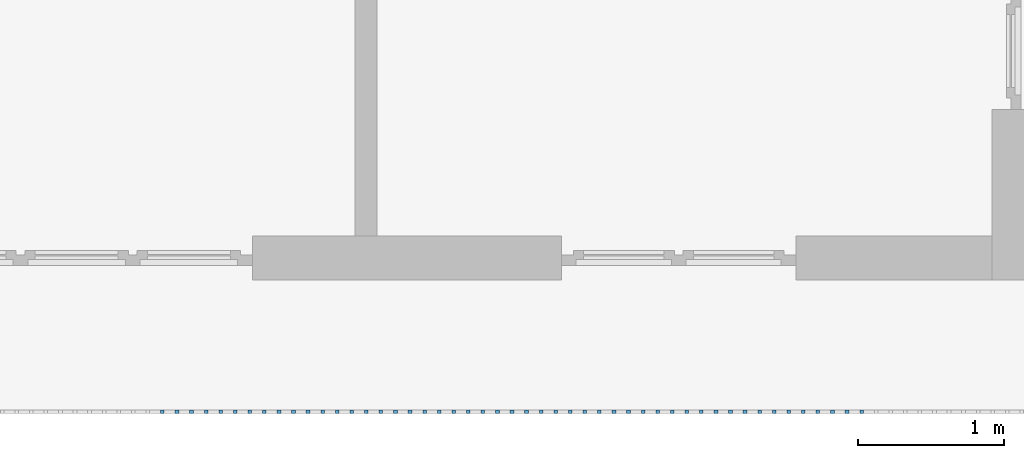
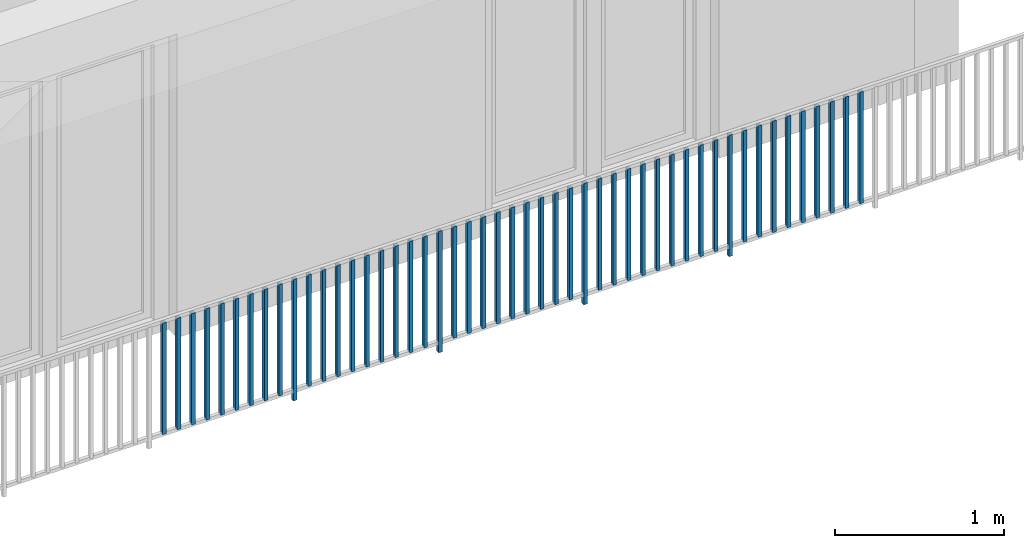
# One storey, part 42 of 54: 49 building element parts, 1 element without a shape of its own.
"""IFC4 building model written with IfcOpenShell, lengths in metres."""

from ifc_helpers import new_model, entity, si_unit, converted_unit, derived_unit, direction, frame, origin_with_axes, place, context, subcontext, project, spatial, polygons, material, type_object, element, aggregate, save


model = new_model("IFC4")

# Units and contexts
model_context = context("Model", 3, precision=1e-05, world=origin_with_axes(), true_north=direction((0.0, 1.0)))
body_context = subcontext(model_context, "Body", "Model", "MODEL_VIEW")
ifc_project = project(units=[si_unit("LENGTHUNIT", "METRE"), si_unit("AREAUNIT", "SQUARE_METRE"), si_unit("VOLUMEUNIT", "CUBIC_METRE"), converted_unit("PLANEANGLEUNIT", "DEGREE", entity("IfcPlaneAngleMeasure", 0.0174532925199), si_unit("PLANEANGLEUNIT", "RADIAN"), dimensions=[0, 0, 0, 0, 0, 0, 0]), converted_unit("TIMEUNIT", "Year", entity("IfcTimeMeasure", 31556926.0), si_unit("TIMEUNIT", "SECOND"), dimensions=[0, 0, 1, 0, 0, 0, 0]), si_unit("MASSUNIT", "GRAM", prefix="KILO"), si_unit("THERMODYNAMICTEMPERATUREUNIT", "DEGREE_CELSIUS"), si_unit("LUMINOUSINTENSITYUNIT", "LUMEN"), si_unit("ENERGYUNIT", "JOULE", prefix="MEGA"), derived_unit("THERMALCONDUCTANCEUNIT", [(si_unit("POWERUNIT", "WATT"), 1), (si_unit("LENGTHUNIT", "METRE"), -1), (si_unit("THERMODYNAMICTEMPERATUREUNIT", "KELVIN"), -1)]), derived_unit("SPECIFICHEATCAPACITYUNIT", [(si_unit("ENERGYUNIT", "JOULE"), 1), (si_unit("MASSUNIT", "GRAM", prefix="KILO"), -1), (si_unit("THERMODYNAMICTEMPERATUREUNIT", "KELVIN"), -1)]), derived_unit("MASSDENSITYUNIT", [(si_unit("MASSUNIT", "GRAM", prefix="KILO"), 1), (si_unit("VOLUMEUNIT", "CUBIC_METRE"), -1)])], contexts=[model_context])

# Site, building, storey, space
site_placement = place(None, origin_with_axes())
site = spatial("IfcSite", under=ifc_project, at=site_placement, CompositionType="ELEMENT")
building_placement = place(site_placement, origin_with_axes())
building = spatial("IfcBuilding", under=site, at=building_placement, CompositionType="ELEMENT")
storey_placement = place(building_placement, frame((0.0, 0.0, 9.18), z_axis=(0.0, 0.0, 1.0), x_axis=(1.0, 0.0, 0.0)))
storey = spatial("IfcBuildingStorey", under=building, at=storey_placement, Name="3. Geschoss", CompositionType="ELEMENT", Elevation=9.18)
space_placement = place(storey_placement, frame((10.2378006196, 9.82118769833, 0.0), z_axis=(0.0, 0.0, 1.0), x_axis=(-1.0, 0.0, 0.0)))
space = spatial("IfcSpace", under=storey, at=space_placement, CompositionType="ELEMENT", PredefinedType="EXTERNAL")

# Railing, building element parts
railing_type = type_object("IfcRailingType", PredefinedType="NOTDEFINED")
railing_placement = place(space_placement, frame((0.0, -7.06315681498e-08, 0.0), z_axis=(0.0, 0.0, 1.0), x_axis=(-1.0, 0.0, 0.0)))
railing = element("IfcRailing", 1, at=railing_placement, inside=space, type_object=railing_type, PredefinedType="NOTDEFINED")
ifc_material = material()
building_element_part_1_placement = place(railing_placement, origin_with_axes())
building_element_part_1 = element("IfcBuildingElementPart", 2, at=building_element_part_1_placement, material=ifc_material, PredefinedType="NOTDEFINED", context=body_context, shape_type="Tessellation", body=[
    polygons([(-6.8515, -20.6625, 0.07), (-6.8515, -20.6375, 0.07), (-6.8515, -20.6375, 0.8775), (-6.8515, -20.6625, 0.8775), (-6.8765, -20.6625, 0.07), (-6.8765, -20.6375, 0.07), (-6.8765, -20.6375, 0.8775), (-6.8765, -20.6625, 0.8775)], [[[1, 2, 3, 4]], [[1, 5, 6, 2]], [[2, 6, 7, 3]], [[4, 3, 7, 8]], [[5, 1, 4, 8]], [[6, 5, 8, 7]]], closed=True),
])
building_element_part_2_placement = place(railing_placement, origin_with_axes())
building_element_part_2 = element("IfcBuildingElementPart", 3, at=building_element_part_2_placement, material=ifc_material, PredefinedType="NOTDEFINED", context=body_context, shape_type="Tessellation", body=[
    polygons([(-6.75202173913, -20.6625, 0.07), (-6.75202173913, -20.6375, 0.07), (-6.75202173913, -20.6375, 0.8775), (-6.75202173913, -20.6625, 0.8775), (-6.77702173913, -20.6625, 0.07), (-6.77702173913, -20.6375, 0.07), (-6.77702173913, -20.6375, 0.8775), (-6.77702173913, -20.6625, 0.8775)], [[[1, 2, 3, 4]], [[1, 5, 6, 2]], [[2, 6, 7, 3]], [[4, 3, 7, 8]], [[5, 1, 4, 8]], [[6, 5, 8, 7]]], closed=True),
])
building_element_part_3_placement = place(railing_placement, origin_with_axes())
building_element_part_3 = element("IfcBuildingElementPart", 4, at=building_element_part_3_placement, material=ifc_material, PredefinedType="NOTDEFINED", context=body_context, shape_type="Tessellation", body=[
    polygons([(-6.65254347826, -20.6625, 0.07), (-6.65254347826, -20.6375, 0.07), (-6.65254347826, -20.6375, 0.8775), (-6.65254347826, -20.6625, 0.8775), (-6.67754347826, -20.6625, 0.07), (-6.67754347826, -20.6375, 0.07), (-6.67754347826, -20.6375, 0.8775), (-6.67754347826, -20.6625, 0.8775)], [[[1, 2, 3, 4]], [[1, 5, 6, 2]], [[2, 6, 7, 3]], [[4, 3, 7, 8]], [[5, 1, 4, 8]], [[6, 5, 8, 7]]], closed=True),
])
building_element_part_4_placement = place(railing_placement, origin_with_axes())
building_element_part_4 = element("IfcBuildingElementPart", 5, at=building_element_part_4_placement, material=ifc_material, PredefinedType="NOTDEFINED", context=body_context, shape_type="Tessellation", body=[
    polygons([(-6.55306521739, -20.6625, 0.07), (-6.55306521739, -20.6375, 0.07), (-6.55306521739, -20.6375, 0.8775), (-6.55306521739, -20.6625, 0.8775), (-6.57806521739, -20.6625, 0.07), (-6.57806521739, -20.6375, 0.07), (-6.57806521739, -20.6375, 0.8775), (-6.57806521739, -20.6625, 0.8775)], [[[1, 2, 3, 4]], [[1, 5, 6, 2]], [[2, 6, 7, 3]], [[4, 3, 7, 8]], [[5, 1, 4, 8]], [[6, 5, 8, 7]]], closed=True),
])
building_element_part_5_placement = place(railing_placement, origin_with_axes())
building_element_part_5 = element("IfcBuildingElementPart", 6, at=building_element_part_5_placement, material=ifc_material, PredefinedType="NOTDEFINED", context=body_context, shape_type="Tessellation", body=[
    polygons([(-6.45358695652, -20.6625, 0.07), (-6.45358695652, -20.6375, 0.07), (-6.45358695652, -20.6375, 0.8775), (-6.45358695652, -20.6625, 0.8775), (-6.47858695652, -20.6625, 0.07), (-6.47858695652, -20.6375, 0.07), (-6.47858695652, -20.6375, 0.8775), (-6.47858695652, -20.6625, 0.8775)], [[[1, 2, 3, 4]], [[1, 5, 6, 2]], [[2, 6, 7, 3]], [[4, 3, 7, 8]], [[5, 1, 4, 8]], [[6, 5, 8, 7]]], closed=True),
])
building_element_part_6_placement = place(railing_placement, origin_with_axes())
building_element_part_6 = element("IfcBuildingElementPart", 7, at=building_element_part_6_placement, material=ifc_material, PredefinedType="NOTDEFINED", context=body_context, shape_type="Tessellation", body=[
    polygons([(-6.35410869565, -20.6625, 0.07), (-6.35410869565, -20.6375, 0.07), (-6.35410869565, -20.6375, 0.8775), (-6.35410869565, -20.6625, 0.8775), (-6.37910869565, -20.6625, 0.07), (-6.37910869565, -20.6375, 0.07), (-6.37910869565, -20.6375, 0.8775), (-6.37910869565, -20.6625, 0.8775)], [[[1, 2, 3, 4]], [[1, 5, 6, 2]], [[2, 6, 7, 3]], [[4, 3, 7, 8]], [[5, 1, 4, 8]], [[6, 5, 8, 7]]], closed=True),
])
building_element_part_7_placement = place(railing_placement, origin_with_axes())
building_element_part_7 = element("IfcBuildingElementPart", 8, at=building_element_part_7_placement, material=ifc_material, PredefinedType="NOTDEFINED", context=body_context, shape_type="Tessellation", body=[
    polygons([(-6.25463043478, -20.6625, 0.07), (-6.25463043478, -20.6375, 0.07), (-6.25463043478, -20.6375, 0.8775), (-6.25463043478, -20.6625, 0.8775), (-6.27963043478, -20.6625, 0.07), (-6.27963043478, -20.6375, 0.07), (-6.27963043478, -20.6375, 0.8775), (-6.27963043478, -20.6625, 0.8775)], [[[1, 2, 3, 4]], [[1, 5, 6, 2]], [[2, 6, 7, 3]], [[4, 3, 7, 8]], [[5, 1, 4, 8]], [[6, 5, 8, 7]]], closed=True),
])
building_element_part_8_placement = place(railing_placement, origin_with_axes())
building_element_part_8 = element("IfcBuildingElementPart", 9, at=building_element_part_8_placement, material=ifc_material, PredefinedType="NOTDEFINED", context=body_context, shape_type="Tessellation", body=[
    polygons([(-6.15515217391, -20.6625, 0.07), (-6.15515217391, -20.6375, 0.07), (-6.15515217391, -20.6375, 0.8775), (-6.15515217391, -20.6625, 0.8775), (-6.18015217391, -20.6625, 0.07), (-6.18015217391, -20.6375, 0.07), (-6.18015217391, -20.6375, 0.8775), (-6.18015217391, -20.6625, 0.8775)], [[[1, 2, 3, 4]], [[1, 5, 6, 2]], [[2, 6, 7, 3]], [[4, 3, 7, 8]], [[5, 1, 4, 8]], [[6, 5, 8, 7]]], closed=True),
])
building_element_part_9_placement = place(railing_placement, origin_with_axes())
building_element_part_9 = element("IfcBuildingElementPart", 10, at=building_element_part_9_placement, material=ifc_material, PredefinedType="NOTDEFINED", context=body_context, shape_type="Tessellation", body=[
    polygons([(-6.05567391304, -20.6625, 0.07), (-6.05567391304, -20.6375, 0.07), (-6.05567391304, -20.6375, 0.8775), (-6.05567391304, -20.6625, 0.8775), (-6.08067391304, -20.6625, 0.07), (-6.08067391304, -20.6375, 0.07), (-6.08067391304, -20.6375, 0.8775), (-6.08067391304, -20.6625, 0.8775)], [[[1, 2, 3, 4]], [[1, 5, 6, 2]], [[2, 6, 7, 3]], [[4, 3, 7, 8]], [[5, 1, 4, 8]], [[6, 5, 8, 7]]], closed=True),
])
building_element_part_10_placement = place(railing_placement, origin_with_axes())
building_element_part_10 = element("IfcBuildingElementPart", 11, at=building_element_part_10_placement, material=ifc_material, PredefinedType="NOTDEFINED", context=body_context, shape_type="Tessellation", body=[
    polygons([(-5.95619565217, -20.6625, 0.0), (-5.95619565217, -20.6375, 0.0), (-5.95619565217, -20.6375, 0.88), (-5.95619565217, -20.6625, 0.88), (-5.98119565217, -20.6625, 0.0), (-5.98119565217, -20.6375, 0.0), (-5.98119565217, -20.6375, 0.88), (-5.98119565217, -20.6625, 0.88)], [[[1, 2, 3, 4]], [[1, 5, 6, 2]], [[2, 6, 7, 3]], [[4, 3, 7, 8]], [[5, 1, 4, 8]], [[6, 5, 8, 7]]], closed=True),
])
building_element_part_11_placement = place(railing_placement, origin_with_axes())
building_element_part_11 = element("IfcBuildingElementPart", 12, at=building_element_part_11_placement, material=ifc_material, PredefinedType="NOTDEFINED", context=body_context, shape_type="Tessellation", body=[
    polygons([(-5.8567173913, -20.6625, 0.07), (-5.8567173913, -20.6375, 0.07), (-5.8567173913, -20.6375, 0.8775), (-5.8567173913, -20.6625, 0.8775), (-5.8817173913, -20.6625, 0.07), (-5.8817173913, -20.6375, 0.07), (-5.8817173913, -20.6375, 0.8775), (-5.8817173913, -20.6625, 0.8775)], [[[1, 2, 3, 4]], [[1, 5, 6, 2]], [[2, 6, 7, 3]], [[4, 3, 7, 8]], [[5, 1, 4, 8]], [[6, 5, 8, 7]]], closed=True),
])
building_element_part_12_placement = place(railing_placement, origin_with_axes())
building_element_part_12 = element("IfcBuildingElementPart", 13, at=building_element_part_12_placement, material=ifc_material, PredefinedType="NOTDEFINED", context=body_context, shape_type="Tessellation", body=[
    polygons([(-5.75723913043, -20.6625, 0.07), (-5.75723913043, -20.6375, 0.07), (-5.75723913043, -20.6375, 0.8775), (-5.75723913043, -20.6625, 0.8775), (-5.78223913043, -20.6625, 0.07), (-5.78223913043, -20.6375, 0.07), (-5.78223913043, -20.6375, 0.8775), (-5.78223913043, -20.6625, 0.8775)], [[[1, 2, 3, 4]], [[1, 5, 6, 2]], [[2, 6, 7, 3]], [[4, 3, 7, 8]], [[5, 1, 4, 8]], [[6, 5, 8, 7]]], closed=True),
])
building_element_part_13_placement = place(railing_placement, origin_with_axes())
building_element_part_13 = element("IfcBuildingElementPart", 14, at=building_element_part_13_placement, material=ifc_material, PredefinedType="NOTDEFINED", context=body_context, shape_type="Tessellation", body=[
    polygons([(-5.65776086957, -20.6625, 0.07), (-5.65776086957, -20.6375, 0.07), (-5.65776086957, -20.6375, 0.8775), (-5.65776086957, -20.6625, 0.8775), (-5.68276086957, -20.6625, 0.07), (-5.68276086957, -20.6375, 0.07), (-5.68276086957, -20.6375, 0.8775), (-5.68276086957, -20.6625, 0.8775)], [[[1, 2, 3, 4]], [[1, 5, 6, 2]], [[2, 6, 7, 3]], [[4, 3, 7, 8]], [[5, 1, 4, 8]], [[6, 5, 8, 7]]], closed=True),
])
building_element_part_14_placement = place(railing_placement, origin_with_axes())
building_element_part_14 = element("IfcBuildingElementPart", 15, at=building_element_part_14_placement, material=ifc_material, PredefinedType="NOTDEFINED", context=body_context, shape_type="Tessellation", body=[
    polygons([(-5.5582826087, -20.6625, 0.07), (-5.5582826087, -20.6375, 0.07), (-5.5582826087, -20.6375, 0.8775), (-5.5582826087, -20.6625, 0.8775), (-5.5832826087, -20.6625, 0.07), (-5.5832826087, -20.6375, 0.07), (-5.5832826087, -20.6375, 0.8775), (-5.5832826087, -20.6625, 0.8775)], [[[1, 2, 3, 4]], [[1, 5, 6, 2]], [[2, 6, 7, 3]], [[4, 3, 7, 8]], [[5, 1, 4, 8]], [[6, 5, 8, 7]]], closed=True),
])
building_element_part_15_placement = place(railing_placement, origin_with_axes())
building_element_part_15 = element("IfcBuildingElementPart", 16, at=building_element_part_15_placement, material=ifc_material, PredefinedType="NOTDEFINED", context=body_context, shape_type="Tessellation", body=[
    polygons([(-5.45880434783, -20.6625, 0.07), (-5.45880434783, -20.6375, 0.07), (-5.45880434783, -20.6375, 0.8775), (-5.45880434783, -20.6625, 0.8775), (-5.48380434783, -20.6625, 0.07), (-5.48380434783, -20.6375, 0.07), (-5.48380434783, -20.6375, 0.8775), (-5.48380434783, -20.6625, 0.8775)], [[[1, 2, 3, 4]], [[1, 5, 6, 2]], [[2, 6, 7, 3]], [[4, 3, 7, 8]], [[5, 1, 4, 8]], [[6, 5, 8, 7]]], closed=True),
])
building_element_part_16_placement = place(railing_placement, origin_with_axes())
building_element_part_16 = element("IfcBuildingElementPart", 17, at=building_element_part_16_placement, material=ifc_material, PredefinedType="NOTDEFINED", context=body_context, shape_type="Tessellation", body=[
    polygons([(-5.35932608696, -20.6625, 0.07), (-5.35932608696, -20.6375, 0.07), (-5.35932608696, -20.6375, 0.8775), (-5.35932608696, -20.6625, 0.8775), (-5.38432608696, -20.6625, 0.07), (-5.38432608696, -20.6375, 0.07), (-5.38432608696, -20.6375, 0.8775), (-5.38432608696, -20.6625, 0.8775)], [[[1, 2, 3, 4]], [[1, 5, 6, 2]], [[2, 6, 7, 3]], [[4, 3, 7, 8]], [[5, 1, 4, 8]], [[6, 5, 8, 7]]], closed=True),
])
building_element_part_17_placement = place(railing_placement, origin_with_axes())
building_element_part_17 = element("IfcBuildingElementPart", 18, at=building_element_part_17_placement, material=ifc_material, PredefinedType="NOTDEFINED", context=body_context, shape_type="Tessellation", body=[
    polygons([(-5.25984782609, -20.6625, 0.07), (-5.25984782609, -20.6375, 0.07), (-5.25984782609, -20.6375, 0.8775), (-5.25984782609, -20.6625, 0.8775), (-5.28484782609, -20.6625, 0.07), (-5.28484782609, -20.6375, 0.07), (-5.28484782609, -20.6375, 0.8775), (-5.28484782609, -20.6625, 0.8775)], [[[1, 2, 3, 4]], [[1, 5, 6, 2]], [[2, 6, 7, 3]], [[4, 3, 7, 8]], [[5, 1, 4, 8]], [[6, 5, 8, 7]]], closed=True),
])
building_element_part_18_placement = place(railing_placement, origin_with_axes())
building_element_part_18 = element("IfcBuildingElementPart", 19, at=building_element_part_18_placement, material=ifc_material, PredefinedType="NOTDEFINED", context=body_context, shape_type="Tessellation", body=[
    polygons([(-5.16036956522, -20.6625, 0.07), (-5.16036956522, -20.6375, 0.07), (-5.16036956522, -20.6375, 0.8775), (-5.16036956522, -20.6625, 0.8775), (-5.18536956522, -20.6625, 0.07), (-5.18536956522, -20.6375, 0.07), (-5.18536956522, -20.6375, 0.8775), (-5.18536956522, -20.6625, 0.8775)], [[[1, 2, 3, 4]], [[1, 5, 6, 2]], [[2, 6, 7, 3]], [[4, 3, 7, 8]], [[5, 1, 4, 8]], [[6, 5, 8, 7]]], closed=True),
])
building_element_part_19_placement = place(railing_placement, origin_with_axes())
building_element_part_19 = element("IfcBuildingElementPart", 20, at=building_element_part_19_placement, material=ifc_material, PredefinedType="NOTDEFINED", context=body_context, shape_type="Tessellation", body=[
    polygons([(-5.06089130435, -20.6625, 0.07), (-5.06089130435, -20.6375, 0.07), (-5.06089130435, -20.6375, 0.8775), (-5.06089130435, -20.6625, 0.8775), (-5.08589130435, -20.6625, 0.07), (-5.08589130435, -20.6375, 0.07), (-5.08589130435, -20.6375, 0.8775), (-5.08589130435, -20.6625, 0.8775)], [[[1, 2, 3, 4]], [[1, 5, 6, 2]], [[2, 6, 7, 3]], [[4, 3, 7, 8]], [[5, 1, 4, 8]], [[6, 5, 8, 7]]], closed=True),
])
building_element_part_20_placement = place(railing_placement, origin_with_axes())
building_element_part_20 = element("IfcBuildingElementPart", 21, at=building_element_part_20_placement, material=ifc_material, PredefinedType="NOTDEFINED", context=body_context, shape_type="Tessellation", body=[
    polygons([(-4.96141304348, -20.6625, 0.0), (-4.96141304348, -20.6375, 0.0), (-4.96141304348, -20.6375, 0.88), (-4.96141304348, -20.6625, 0.88), (-4.98641304348, -20.6625, 0.0), (-4.98641304348, -20.6375, 0.0), (-4.98641304348, -20.6375, 0.88), (-4.98641304348, -20.6625, 0.88)], [[[1, 2, 3, 4]], [[1, 5, 6, 2]], [[2, 6, 7, 3]], [[4, 3, 7, 8]], [[5, 1, 4, 8]], [[6, 5, 8, 7]]], closed=True),
])
building_element_part_21_placement = place(railing_placement, origin_with_axes())
building_element_part_21 = element("IfcBuildingElementPart", 22, at=building_element_part_21_placement, material=ifc_material, PredefinedType="NOTDEFINED", context=body_context, shape_type="Tessellation", body=[
    polygons([(-4.86193478261, -20.6625, 0.07), (-4.86193478261, -20.6375, 0.07), (-4.86193478261, -20.6375, 0.8775), (-4.86193478261, -20.6625, 0.8775), (-4.88693478261, -20.6625, 0.07), (-4.88693478261, -20.6375, 0.07), (-4.88693478261, -20.6375, 0.8775), (-4.88693478261, -20.6625, 0.8775)], [[[1, 2, 3, 4]], [[1, 5, 6, 2]], [[2, 6, 7, 3]], [[4, 3, 7, 8]], [[5, 1, 4, 8]], [[6, 5, 8, 7]]], closed=True),
])
building_element_part_22_placement = place(railing_placement, origin_with_axes())
building_element_part_22 = element("IfcBuildingElementPart", 23, at=building_element_part_22_placement, material=ifc_material, PredefinedType="NOTDEFINED", context=body_context, shape_type="Tessellation", body=[
    polygons([(-4.76245652174, -20.6625, 0.07), (-4.76245652174, -20.6375, 0.07), (-4.76245652174, -20.6375, 0.8775), (-4.76245652174, -20.6625, 0.8775), (-4.78745652174, -20.6625, 0.07), (-4.78745652174, -20.6375, 0.07), (-4.78745652174, -20.6375, 0.8775), (-4.78745652174, -20.6625, 0.8775)], [[[1, 2, 3, 4]], [[1, 5, 6, 2]], [[2, 6, 7, 3]], [[4, 3, 7, 8]], [[5, 1, 4, 8]], [[6, 5, 8, 7]]], closed=True),
])
building_element_part_23_placement = place(railing_placement, origin_with_axes())
building_element_part_23 = element("IfcBuildingElementPart", 24, at=building_element_part_23_placement, material=ifc_material, PredefinedType="NOTDEFINED", context=body_context, shape_type="Tessellation", body=[
    polygons([(-4.66297826087, -20.6625, 0.07), (-4.66297826087, -20.6375, 0.07), (-4.66297826087, -20.6375, 0.8775), (-4.66297826087, -20.6625, 0.8775), (-4.68797826087, -20.6625, 0.07), (-4.68797826087, -20.6375, 0.07), (-4.68797826087, -20.6375, 0.8775), (-4.68797826087, -20.6625, 0.8775)], [[[1, 2, 3, 4]], [[1, 5, 6, 2]], [[2, 6, 7, 3]], [[4, 3, 7, 8]], [[5, 1, 4, 8]], [[6, 5, 8, 7]]], closed=True),
])
building_element_part_24_placement = place(railing_placement, origin_with_axes())
building_element_part_24 = element("IfcBuildingElementPart", 25, at=building_element_part_24_placement, material=ifc_material, PredefinedType="NOTDEFINED", context=body_context, shape_type="Tessellation", body=[
    polygons([(-4.5635, -20.6625, 0.07), (-4.5635, -20.6375, 0.07), (-4.5635, -20.6375, 0.8775), (-4.5635, -20.6625, 0.8775), (-4.5885, -20.6625, 0.07), (-4.5885, -20.6375, 0.07), (-4.5885, -20.6375, 0.8775), (-4.5885, -20.6625, 0.8775)], [[[1, 2, 3, 4]], [[1, 5, 6, 2]], [[2, 6, 7, 3]], [[4, 3, 7, 8]], [[5, 1, 4, 8]], [[6, 5, 8, 7]]], closed=True),
])
building_element_part_25_placement = place(railing_placement, origin_with_axes())
building_element_part_25 = element("IfcBuildingElementPart", 26, at=building_element_part_25_placement, material=ifc_material, PredefinedType="NOTDEFINED", context=body_context, shape_type="Tessellation", body=[
    polygons([(-4.46402173913, -20.6625, 0.07), (-4.46402173913, -20.6375, 0.07), (-4.46402173913, -20.6375, 0.8775), (-4.46402173913, -20.6625, 0.8775), (-4.48902173913, -20.6625, 0.07), (-4.48902173913, -20.6375, 0.07), (-4.48902173913, -20.6375, 0.8775), (-4.48902173913, -20.6625, 0.8775)], [[[1, 2, 3, 4]], [[1, 5, 6, 2]], [[2, 6, 7, 3]], [[4, 3, 7, 8]], [[5, 1, 4, 8]], [[6, 5, 8, 7]]], closed=True),
])
building_element_part_26_placement = place(railing_placement, origin_with_axes())
building_element_part_26 = element("IfcBuildingElementPart", 27, at=building_element_part_26_placement, material=ifc_material, PredefinedType="NOTDEFINED", context=body_context, shape_type="Tessellation", body=[
    polygons([(-4.36454347826, -20.6625, 0.07), (-4.36454347826, -20.6375, 0.07), (-4.36454347826, -20.6375, 0.8775), (-4.36454347826, -20.6625, 0.8775), (-4.38954347826, -20.6625, 0.07), (-4.38954347826, -20.6375, 0.07), (-4.38954347826, -20.6375, 0.8775), (-4.38954347826, -20.6625, 0.8775)], [[[1, 2, 3, 4]], [[1, 5, 6, 2]], [[2, 6, 7, 3]], [[4, 3, 7, 8]], [[5, 1, 4, 8]], [[6, 5, 8, 7]]], closed=True),
])
building_element_part_27_placement = place(railing_placement, origin_with_axes())
building_element_part_27 = element("IfcBuildingElementPart", 28, at=building_element_part_27_placement, material=ifc_material, PredefinedType="NOTDEFINED", context=body_context, shape_type="Tessellation", body=[
    polygons([(-4.26506521739, -20.6625, 0.07), (-4.26506521739, -20.6375, 0.07), (-4.26506521739, -20.6375, 0.8775), (-4.26506521739, -20.6625, 0.8775), (-4.29006521739, -20.6625, 0.07), (-4.29006521739, -20.6375, 0.07), (-4.29006521739, -20.6375, 0.8775), (-4.29006521739, -20.6625, 0.8775)], [[[1, 2, 3, 4]], [[1, 5, 6, 2]], [[2, 6, 7, 3]], [[4, 3, 7, 8]], [[5, 1, 4, 8]], [[6, 5, 8, 7]]], closed=True),
])
building_element_part_28_placement = place(railing_placement, origin_with_axes())
building_element_part_28 = element("IfcBuildingElementPart", 29, at=building_element_part_28_placement, material=ifc_material, PredefinedType="NOTDEFINED", context=body_context, shape_type="Tessellation", body=[
    polygons([(-4.16558695652, -20.6625, 0.07), (-4.16558695652, -20.6375, 0.07), (-4.16558695652, -20.6375, 0.8775), (-4.16558695652, -20.6625, 0.8775), (-4.19058695652, -20.6625, 0.07), (-4.19058695652, -20.6375, 0.07), (-4.19058695652, -20.6375, 0.8775), (-4.19058695652, -20.6625, 0.8775)], [[[1, 2, 3, 4]], [[1, 5, 6, 2]], [[2, 6, 7, 3]], [[4, 3, 7, 8]], [[5, 1, 4, 8]], [[6, 5, 8, 7]]], closed=True),
])
building_element_part_29_placement = place(railing_placement, origin_with_axes())
building_element_part_29 = element("IfcBuildingElementPart", 30, at=building_element_part_29_placement, material=ifc_material, PredefinedType="NOTDEFINED", context=body_context, shape_type="Tessellation", body=[
    polygons([(-4.06610869565, -20.6625, 0.07), (-4.06610869565, -20.6375, 0.07), (-4.06610869565, -20.6375, 0.8775), (-4.06610869565, -20.6625, 0.8775), (-4.09110869565, -20.6625, 0.07), (-4.09110869565, -20.6375, 0.07), (-4.09110869565, -20.6375, 0.8775), (-4.09110869565, -20.6625, 0.8775)], [[[1, 2, 3, 4]], [[1, 5, 6, 2]], [[2, 6, 7, 3]], [[4, 3, 7, 8]], [[5, 1, 4, 8]], [[6, 5, 8, 7]]], closed=True),
])
building_element_part_30_placement = place(railing_placement, origin_with_axes())
building_element_part_30 = element("IfcBuildingElementPart", 31, at=building_element_part_30_placement, material=ifc_material, PredefinedType="NOTDEFINED", context=body_context, shape_type="Tessellation", body=[
    polygons([(-3.96663043478, -20.6625, 0.0), (-3.96663043478, -20.6375, 0.0), (-3.96663043478, -20.6375, 0.88), (-3.96663043478, -20.6625, 0.88), (-3.99163043478, -20.6625, 0.0), (-3.99163043478, -20.6375, 0.0), (-3.99163043478, -20.6375, 0.88), (-3.99163043478, -20.6625, 0.88)], [[[1, 2, 3, 4]], [[1, 5, 6, 2]], [[2, 6, 7, 3]], [[4, 3, 7, 8]], [[5, 1, 4, 8]], [[6, 5, 8, 7]]], closed=True),
])
building_element_part_31_placement = place(railing_placement, origin_with_axes())
building_element_part_31 = element("IfcBuildingElementPart", 32, at=building_element_part_31_placement, material=ifc_material, PredefinedType="NOTDEFINED", context=body_context, shape_type="Tessellation", body=[
    polygons([(-3.86715217391, -20.6625, 0.07), (-3.86715217391, -20.6375, 0.07), (-3.86715217391, -20.6375, 0.8775), (-3.86715217391, -20.6625, 0.8775), (-3.89215217391, -20.6625, 0.07), (-3.89215217391, -20.6375, 0.07), (-3.89215217391, -20.6375, 0.8775), (-3.89215217391, -20.6625, 0.8775)], [[[1, 2, 3, 4]], [[1, 5, 6, 2]], [[2, 6, 7, 3]], [[4, 3, 7, 8]], [[5, 1, 4, 8]], [[6, 5, 8, 7]]], closed=True),
])
building_element_part_32_placement = place(railing_placement, origin_with_axes())
building_element_part_32 = element("IfcBuildingElementPart", 33, at=building_element_part_32_placement, material=ifc_material, PredefinedType="NOTDEFINED", context=body_context, shape_type="Tessellation", body=[
    polygons([(-3.76767391304, -20.6625, 0.07), (-3.76767391304, -20.6375, 0.07), (-3.76767391304, -20.6375, 0.8775), (-3.76767391304, -20.6625, 0.8775), (-3.79267391304, -20.6625, 0.07), (-3.79267391304, -20.6375, 0.07), (-3.79267391304, -20.6375, 0.8775), (-3.79267391304, -20.6625, 0.8775)], [[[1, 2, 3, 4]], [[1, 5, 6, 2]], [[2, 6, 7, 3]], [[4, 3, 7, 8]], [[5, 1, 4, 8]], [[6, 5, 8, 7]]], closed=True),
])
building_element_part_33_placement = place(railing_placement, origin_with_axes())
building_element_part_33 = element("IfcBuildingElementPart", 34, at=building_element_part_33_placement, material=ifc_material, PredefinedType="NOTDEFINED", context=body_context, shape_type="Tessellation", body=[
    polygons([(-3.66819565217, -20.6625, 0.07), (-3.66819565217, -20.6375, 0.07), (-3.66819565217, -20.6375, 0.8775), (-3.66819565217, -20.6625, 0.8775), (-3.69319565217, -20.6625, 0.07), (-3.69319565217, -20.6375, 0.07), (-3.69319565217, -20.6375, 0.8775), (-3.69319565217, -20.6625, 0.8775)], [[[1, 2, 3, 4]], [[1, 5, 6, 2]], [[2, 6, 7, 3]], [[4, 3, 7, 8]], [[5, 1, 4, 8]], [[6, 5, 8, 7]]], closed=True),
])
building_element_part_34_placement = place(railing_placement, origin_with_axes())
building_element_part_34 = element("IfcBuildingElementPart", 35, at=building_element_part_34_placement, material=ifc_material, PredefinedType="NOTDEFINED", context=body_context, shape_type="Tessellation", body=[
    polygons([(-3.5687173913, -20.6625, 0.07), (-3.5687173913, -20.6375, 0.07), (-3.5687173913, -20.6375, 0.8775), (-3.5687173913, -20.6625, 0.8775), (-3.5937173913, -20.6625, 0.07), (-3.5937173913, -20.6375, 0.07), (-3.5937173913, -20.6375, 0.8775), (-3.5937173913, -20.6625, 0.8775)], [[[1, 2, 3, 4]], [[1, 5, 6, 2]], [[2, 6, 7, 3]], [[4, 3, 7, 8]], [[5, 1, 4, 8]], [[6, 5, 8, 7]]], closed=True),
])
building_element_part_35_placement = place(railing_placement, origin_with_axes())
building_element_part_35 = element("IfcBuildingElementPart", 36, at=building_element_part_35_placement, material=ifc_material, PredefinedType="NOTDEFINED", context=body_context, shape_type="Tessellation", body=[
    polygons([(-3.46923913043, -20.6625, 0.07), (-3.46923913043, -20.6375, 0.07), (-3.46923913043, -20.6375, 0.8775), (-3.46923913043, -20.6625, 0.8775), (-3.49423913043, -20.6625, 0.07), (-3.49423913043, -20.6375, 0.07), (-3.49423913043, -20.6375, 0.8775), (-3.49423913043, -20.6625, 0.8775)], [[[1, 2, 3, 4]], [[1, 5, 6, 2]], [[2, 6, 7, 3]], [[4, 3, 7, 8]], [[5, 1, 4, 8]], [[6, 5, 8, 7]]], closed=True),
])
building_element_part_36_placement = place(railing_placement, origin_with_axes())
building_element_part_36 = element("IfcBuildingElementPart", 37, at=building_element_part_36_placement, material=ifc_material, PredefinedType="NOTDEFINED", context=body_context, shape_type="Tessellation", body=[
    polygons([(-3.36976086957, -20.6625, 0.07), (-3.36976086957, -20.6375, 0.07), (-3.36976086957, -20.6375, 0.8775), (-3.36976086957, -20.6625, 0.8775), (-3.39476086957, -20.6625, 0.07), (-3.39476086957, -20.6375, 0.07), (-3.39476086957, -20.6375, 0.8775), (-3.39476086957, -20.6625, 0.8775)], [[[1, 2, 3, 4]], [[1, 5, 6, 2]], [[2, 6, 7, 3]], [[4, 3, 7, 8]], [[5, 1, 4, 8]], [[6, 5, 8, 7]]], closed=True),
])
building_element_part_37_placement = place(railing_placement, origin_with_axes())
building_element_part_37 = element("IfcBuildingElementPart", 38, at=building_element_part_37_placement, material=ifc_material, PredefinedType="NOTDEFINED", context=body_context, shape_type="Tessellation", body=[
    polygons([(-3.2702826087, -20.6625, 0.07), (-3.2702826087, -20.6375, 0.07), (-3.2702826087, -20.6375, 0.8775), (-3.2702826087, -20.6625, 0.8775), (-3.2952826087, -20.6625, 0.07), (-3.2952826087, -20.6375, 0.07), (-3.2952826087, -20.6375, 0.8775), (-3.2952826087, -20.6625, 0.8775)], [[[1, 2, 3, 4]], [[1, 5, 6, 2]], [[2, 6, 7, 3]], [[4, 3, 7, 8]], [[5, 1, 4, 8]], [[6, 5, 8, 7]]], closed=True),
])
building_element_part_38_placement = place(railing_placement, origin_with_axes())
building_element_part_38 = element("IfcBuildingElementPart", 39, at=building_element_part_38_placement, material=ifc_material, PredefinedType="NOTDEFINED", context=body_context, shape_type="Tessellation", body=[
    polygons([(-3.17080434783, -20.6625, 0.07), (-3.17080434783, -20.6375, 0.07), (-3.17080434783, -20.6375, 0.8775), (-3.17080434783, -20.6625, 0.8775), (-3.19580434783, -20.6625, 0.07), (-3.19580434783, -20.6375, 0.07), (-3.19580434783, -20.6375, 0.8775), (-3.19580434783, -20.6625, 0.8775)], [[[1, 2, 3, 4]], [[1, 5, 6, 2]], [[2, 6, 7, 3]], [[4, 3, 7, 8]], [[5, 1, 4, 8]], [[6, 5, 8, 7]]], closed=True),
])
building_element_part_39_placement = place(railing_placement, origin_with_axes())
building_element_part_39 = element("IfcBuildingElementPart", 40, at=building_element_part_39_placement, material=ifc_material, PredefinedType="NOTDEFINED", context=body_context, shape_type="Tessellation", body=[
    polygons([(-3.07132608696, -20.6625, 0.07), (-3.07132608696, -20.6375, 0.07), (-3.07132608696, -20.6375, 0.8775), (-3.07132608696, -20.6625, 0.8775), (-3.09632608696, -20.6625, 0.07), (-3.09632608696, -20.6375, 0.07), (-3.09632608696, -20.6375, 0.8775), (-3.09632608696, -20.6625, 0.8775)], [[[1, 2, 3, 4]], [[1, 5, 6, 2]], [[2, 6, 7, 3]], [[4, 3, 7, 8]], [[5, 1, 4, 8]], [[6, 5, 8, 7]]], closed=True),
])
building_element_part_40_placement = place(railing_placement, origin_with_axes())
building_element_part_40 = element("IfcBuildingElementPart", 41, at=building_element_part_40_placement, material=ifc_material, PredefinedType="NOTDEFINED", context=body_context, shape_type="Tessellation", body=[
    polygons([(-2.97184782609, -20.6625, 0.0), (-2.97184782609, -20.6375, 0.0), (-2.97184782609, -20.6375, 0.88), (-2.97184782609, -20.6625, 0.88), (-2.99684782609, -20.6625, 0.0), (-2.99684782609, -20.6375, 0.0), (-2.99684782609, -20.6375, 0.88), (-2.99684782609, -20.6625, 0.88)], [[[1, 2, 3, 4]], [[1, 5, 6, 2]], [[2, 6, 7, 3]], [[4, 3, 7, 8]], [[5, 1, 4, 8]], [[6, 5, 8, 7]]], closed=True),
])
building_element_part_41_placement = place(railing_placement, origin_with_axes())
building_element_part_41 = element("IfcBuildingElementPart", 42, at=building_element_part_41_placement, material=ifc_material, PredefinedType="NOTDEFINED", context=body_context, shape_type="Tessellation", body=[
    polygons([(-2.87236956522, -20.6625, 0.07), (-2.87236956522, -20.6375, 0.07), (-2.87236956522, -20.6375, 0.8775), (-2.87236956522, -20.6625, 0.8775), (-2.89736956522, -20.6625, 0.07), (-2.89736956522, -20.6375, 0.07), (-2.89736956522, -20.6375, 0.8775), (-2.89736956522, -20.6625, 0.8775)], [[[1, 2, 3, 4]], [[1, 5, 6, 2]], [[2, 6, 7, 3]], [[4, 3, 7, 8]], [[5, 1, 4, 8]], [[6, 5, 8, 7]]], closed=True),
])
building_element_part_42_placement = place(railing_placement, origin_with_axes())
building_element_part_42 = element("IfcBuildingElementPart", 43, at=building_element_part_42_placement, material=ifc_material, PredefinedType="NOTDEFINED", context=body_context, shape_type="Tessellation", body=[
    polygons([(-2.77289130435, -20.6625, 0.07), (-2.77289130435, -20.6375, 0.07), (-2.77289130435, -20.6375, 0.8775), (-2.77289130435, -20.6625, 0.8775), (-2.79789130435, -20.6625, 0.07), (-2.79789130435, -20.6375, 0.07), (-2.79789130435, -20.6375, 0.8775), (-2.79789130435, -20.6625, 0.8775)], [[[1, 2, 3, 4]], [[1, 5, 6, 2]], [[2, 6, 7, 3]], [[4, 3, 7, 8]], [[5, 1, 4, 8]], [[6, 5, 8, 7]]], closed=True),
])
building_element_part_43_placement = place(railing_placement, origin_with_axes())
building_element_part_43 = element("IfcBuildingElementPart", 44, at=building_element_part_43_placement, material=ifc_material, PredefinedType="NOTDEFINED", context=body_context, shape_type="Tessellation", body=[
    polygons([(-2.67341304348, -20.6625, 0.07), (-2.67341304348, -20.6375, 0.07), (-2.67341304348, -20.6375, 0.8775), (-2.67341304348, -20.6625, 0.8775), (-2.69841304348, -20.6625, 0.07), (-2.69841304348, -20.6375, 0.07), (-2.69841304348, -20.6375, 0.8775), (-2.69841304348, -20.6625, 0.8775)], [[[1, 2, 3, 4]], [[1, 5, 6, 2]], [[2, 6, 7, 3]], [[4, 3, 7, 8]], [[5, 1, 4, 8]], [[6, 5, 8, 7]]], closed=True),
])
building_element_part_44_placement = place(railing_placement, origin_with_axes())
building_element_part_44 = element("IfcBuildingElementPart", 45, at=building_element_part_44_placement, material=ifc_material, PredefinedType="NOTDEFINED", context=body_context, shape_type="Tessellation", body=[
    polygons([(-2.57393478261, -20.6625, 0.07), (-2.57393478261, -20.6375, 0.07), (-2.57393478261, -20.6375, 0.8775), (-2.57393478261, -20.6625, 0.8775), (-2.59893478261, -20.6625, 0.07), (-2.59893478261, -20.6375, 0.07), (-2.59893478261, -20.6375, 0.8775), (-2.59893478261, -20.6625, 0.8775)], [[[1, 2, 3, 4]], [[1, 5, 6, 2]], [[2, 6, 7, 3]], [[4, 3, 7, 8]], [[5, 1, 4, 8]], [[6, 5, 8, 7]]], closed=True),
])
building_element_part_45_placement = place(railing_placement, origin_with_axes())
building_element_part_45 = element("IfcBuildingElementPart", 46, at=building_element_part_45_placement, material=ifc_material, PredefinedType="NOTDEFINED", context=body_context, shape_type="Tessellation", body=[
    polygons([(-2.47445652174, -20.6625, 0.07), (-2.47445652174, -20.6375, 0.07), (-2.47445652174, -20.6375, 0.8775), (-2.47445652174, -20.6625, 0.8775), (-2.49945652174, -20.6625, 0.07), (-2.49945652174, -20.6375, 0.07), (-2.49945652174, -20.6375, 0.8775), (-2.49945652174, -20.6625, 0.8775)], [[[1, 2, 3, 4]], [[1, 5, 6, 2]], [[2, 6, 7, 3]], [[4, 3, 7, 8]], [[5, 1, 4, 8]], [[6, 5, 8, 7]]], closed=True),
])
building_element_part_46_placement = place(railing_placement, origin_with_axes())
building_element_part_46 = element("IfcBuildingElementPart", 47, at=building_element_part_46_placement, material=ifc_material, PredefinedType="NOTDEFINED", context=body_context, shape_type="Tessellation", body=[
    polygons([(-2.37497826087, -20.6625, 0.07), (-2.37497826087, -20.6375, 0.07), (-2.37497826087, -20.6375, 0.8775), (-2.37497826087, -20.6625, 0.8775), (-2.39997826087, -20.6625, 0.07), (-2.39997826087, -20.6375, 0.07), (-2.39997826087, -20.6375, 0.8775), (-2.39997826087, -20.6625, 0.8775)], [[[1, 2, 3, 4]], [[1, 5, 6, 2]], [[2, 6, 7, 3]], [[4, 3, 7, 8]], [[5, 1, 4, 8]], [[6, 5, 8, 7]]], closed=True),
])
building_element_part_47_placement = place(railing_placement, origin_with_axes())
building_element_part_47 = element("IfcBuildingElementPart", 48, at=building_element_part_47_placement, material=ifc_material, PredefinedType="NOTDEFINED", context=body_context, shape_type="Tessellation", body=[
    polygons([(-2.2755, -20.6625, 0.07), (-2.2755, -20.6375, 0.07), (-2.2755, -20.6375, 0.8775), (-2.2755, -20.6625, 0.8775), (-2.3005, -20.6625, 0.07), (-2.3005, -20.6375, 0.07), (-2.3005, -20.6375, 0.8775), (-2.3005, -20.6625, 0.8775)], [[[1, 2, 3, 4]], [[1, 5, 6, 2]], [[2, 6, 7, 3]], [[4, 3, 7, 8]], [[5, 1, 4, 8]], [[6, 5, 8, 7]]], closed=True),
])
building_element_part_48_placement = place(railing_placement, origin_with_axes())
building_element_part_48 = element("IfcBuildingElementPart", 49, at=building_element_part_48_placement, material=ifc_material, PredefinedType="NOTDEFINED", context=body_context, shape_type="Tessellation", body=[
    polygons([(-2.17602173913, -20.6625, 0.07), (-2.17602173913, -20.6375, 0.07), (-2.17602173913, -20.6375, 0.8775), (-2.17602173913, -20.6625, 0.8775), (-2.20102173913, -20.6625, 0.07), (-2.20102173913, -20.6375, 0.07), (-2.20102173913, -20.6375, 0.8775), (-2.20102173913, -20.6625, 0.8775)], [[[1, 2, 3, 4]], [[1, 5, 6, 2]], [[2, 6, 7, 3]], [[4, 3, 7, 8]], [[5, 1, 4, 8]], [[6, 5, 8, 7]]], closed=True),
])
building_element_part_49_placement = place(railing_placement, origin_with_axes())
building_element_part_49 = element("IfcBuildingElementPart", 50, at=building_element_part_49_placement, material=ifc_material, PredefinedType="NOTDEFINED", context=body_context, shape_type="Tessellation", body=[
    polygons([(-2.07654347826, -20.6625, 0.07), (-2.07654347826, -20.6375, 0.07), (-2.07654347826, -20.6375, 0.8775), (-2.07654347826, -20.6625, 0.8775), (-2.10154347826, -20.6625, 0.07), (-2.10154347826, -20.6375, 0.07), (-2.10154347826, -20.6375, 0.8775), (-2.10154347826, -20.6625, 0.8775)], [[[1, 2, 3, 4]], [[1, 5, 6, 2]], [[2, 6, 7, 3]], [[4, 3, 7, 8]], [[5, 1, 4, 8]], [[6, 5, 8, 7]]], closed=True),
])
aggregate(railing, [building_element_part_1, building_element_part_2, building_element_part_3, building_element_part_4, building_element_part_5, building_element_part_6, building_element_part_7, building_element_part_8, building_element_part_9, building_element_part_10, building_element_part_11, building_element_part_12, building_element_part_13, building_element_part_14, building_element_part_15, building_element_part_16, building_element_part_17, building_element_part_18, building_element_part_19, building_element_part_20, building_element_part_21, building_element_part_22, building_element_part_23, building_element_part_24, building_element_part_25, building_element_part_26, building_element_part_27, building_element_part_28, building_element_part_29, building_element_part_30, building_element_part_31, building_element_part_32, building_element_part_33, building_element_part_34, building_element_part_35, building_element_part_36, building_element_part_37, building_element_part_38, building_element_part_39, building_element_part_40, building_element_part_41, building_element_part_42, building_element_part_43, building_element_part_44, building_element_part_45, building_element_part_46, building_element_part_47, building_element_part_48, building_element_part_49])

save(model, "model.ifc")
